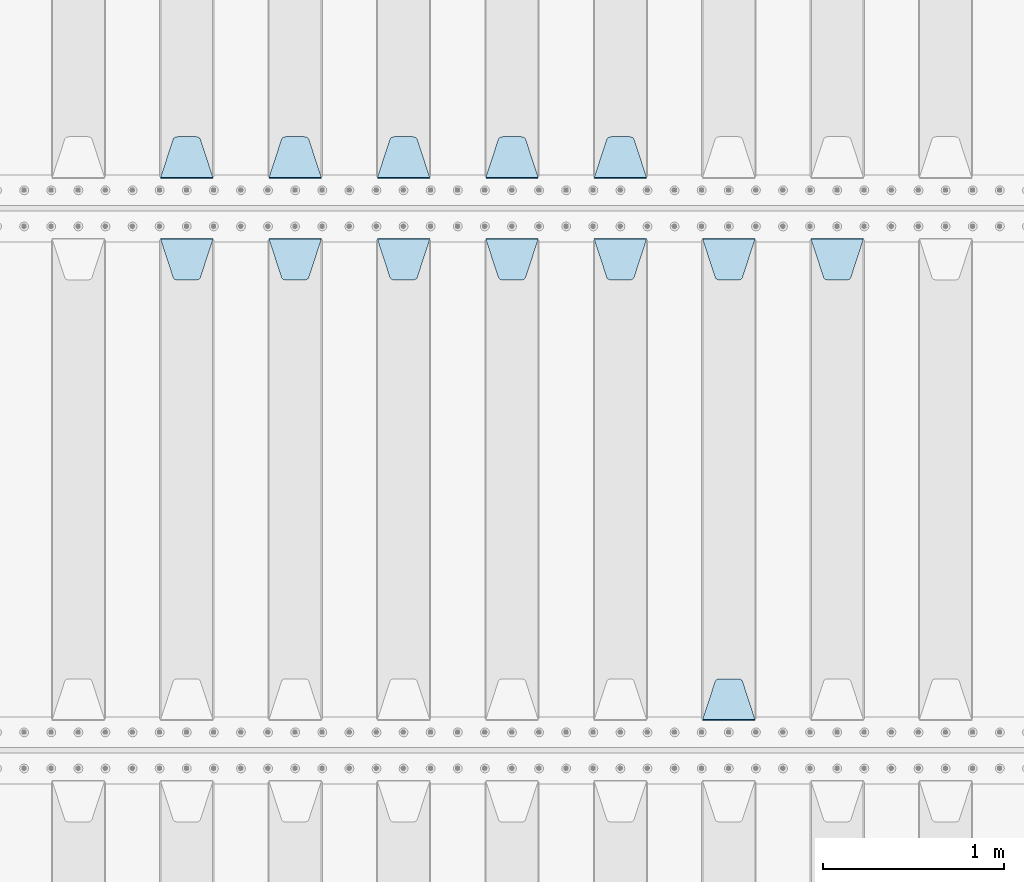
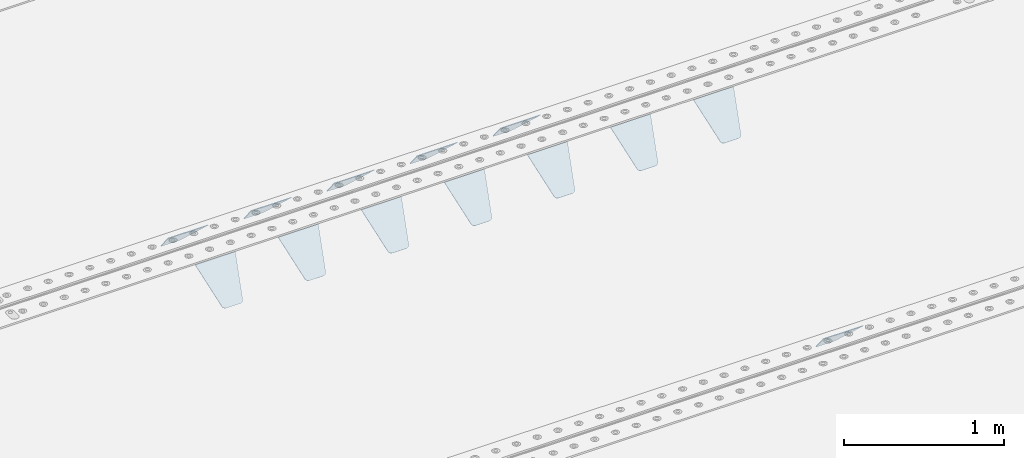
# One storey, part 214 of 257: 13 plates.
"""IFC2X3 building model written with IfcOpenShell, lengths in millimetres."""

from ifc_helpers import new_model, si_unit, frame, origin_with_axes, place, context, subcontext, project, spatial, faceted_brep, material, type_object, element, save


model = new_model("IFC2X3")

# Units and contexts
model_context = context("Model", 3, precision=1e-05, world=origin_with_axes())
body_context = subcontext(model_context, "Body", "Model", "MODEL_VIEW")
ifc_project = project(units=[si_unit("LENGTHUNIT", "METRE", prefix="MILLI"), si_unit("AREAUNIT", "SQUARE_METRE"), si_unit("VOLUMEUNIT", "CUBIC_METRE"), si_unit("MASSUNIT", "GRAM", prefix="KILO"), si_unit("TIMEUNIT", "SECOND"), si_unit("PLANEANGLEUNIT", "RADIAN"), si_unit("SOLIDANGLEUNIT", "STERADIAN"), si_unit("THERMODYNAMICTEMPERATUREUNIT", "DEGREE_CELSIUS"), si_unit("LUMINOUSINTENSITYUNIT", "LUMEN")], contexts=[model_context])

# Site, building, storey
site_placement = place(None, origin_with_axes())
site = spatial("IfcSite", under=ifc_project, at=site_placement, CompositionType="ELEMENT")
building_placement = place(site_placement, origin_with_axes())
building = spatial("IfcBuilding", under=site, at=building_placement, Name="Standard", CompositionType="ELEMENT")
storey_placement = place(building_placement, origin_with_axes())
storey = spatial("IfcBuildingStorey", under=building, at=storey_placement, Name="Undefined", CompositionType="ELEMENT", Elevation=0.0)

# Plates
ifc_material = material(Name="STEEL/S355N")
plate_type = type_object("IfcPlateType", PredefinedType="NOTDEFINED")
plate_1_placement = place(storey_placement, frame((51995.0, 6168.23223304703, -1.76776695296758), z_axis=(0.0, 0.707106781186547, -0.707106781186548), x_axis=(-1.0, 0.0, 0.0)))
element("IfcPlate", 1, at=plate_1_placement, inside=storey, type_object=plate_type, material=ifc_material, context=body_context, shape_type="Brep", body=[
    faceted_brep([(0.0, -2.5, 0.0), (69.345504679477, -2.50000000000091, 300.17173142483), (69.345504679477, 2.5, 300.171731424831), (0.0, 2.5, 0.0), (70.927406119954, -2.50000000000091, 304.8974424154), (70.927406119954, 2.5, 304.8974424154), (73.3818627772271, -2.50000000000091, 309.234538108527), (73.3818627772271, 2.49999999999909, 309.234538108527), (76.6187032999587, -2.5, 313.023683126103), (76.6187032999587, 2.5, 313.023683126103), (80.5190132705029, -2.5, 316.125672595372), (80.5190132705029, 2.5, 316.125672595371), (84.9395038596849, -2.5, 318.426546230476), (84.9395038596849, 2.5, 318.426546230477), (89.7177759439219, -2.5, 319.841774983275), (89.7177759439219, 2.5, 319.841774983275), (94.6782862926484, -2.5, 320.319366455079), (94.6782862926484, 2.5, 320.319366455079), (195.321713707352, -2.5, 320.319366455079), (195.321713707352, 2.5, 320.319366455079), (200.282224056078, -2.5, 319.841774983275), (200.282224056078, 2.49999999999909, 319.841774983275), (205.060496140315, -2.5, 318.426546230476), (205.060496140315, 2.49999999999909, 318.426546230475), (209.480986729497, -2.5, 316.125672595371), (209.480986729497, 2.5, 316.125672595371), (213.381296700041, -2.50000000000091, 313.023683126102), (213.381296700041, 2.5, 313.023683126103), (216.618137222766, -2.50000000000091, 309.234538108527), (216.618137222766, 2.5, 309.234538108527), (219.072593880039, -2.5, 304.897442415399), (219.072593880039, 2.5, 304.897442415399), (220.654495320523, -2.50000000000091, 300.17173142483), (220.654495320523, 2.5, 300.171731424831), (290.0, -2.50000000000091, 0.0), (290.0, 2.5, 9.09494701772928e-13)], [[[0, 1, 2, 3]], [[1, 4, 5, 2]], [[4, 6, 7, 5]], [[6, 8, 9, 7]], [[8, 10, 11, 9]], [[10, 12, 13, 11]], [[12, 14, 15, 13]], [[14, 16, 17, 15]], [[16, 18, 19, 17]], [[18, 20, 21, 19]], [[20, 22, 23, 21]], [[22, 24, 25, 23]], [[24, 26, 27, 25]], [[26, 28, 29, 27]], [[28, 30, 31, 29]], [[30, 32, 33, 31]], [[32, 34, 35, 33]], [[34, 0, 3, 35]], [[5, 7, 9, 11, 13, 15, 17, 19, 21, 23, 25, 27, 29, 31, 33, 35, 3, 2]], [[34, 32, 30, 28, 26, 24, 22, 20, 18, 16, 14, 12, 10, 8, 6, 4, 1, 0]]]),
])
plate_2_placement = place(storey_placement, frame((51395.0, 6168.23223304703, -1.76776695296758), z_axis=(0.0, 0.707106781186547, -0.707106781186548), x_axis=(-1.0, 0.0, 0.0)))
element("IfcPlate", 2, at=plate_2_placement, inside=storey, type_object=plate_type, material=ifc_material, context=body_context, shape_type="Brep", body=[
    faceted_brep([(0.0, -2.5, 0.0), (69.345504679477, -2.50000000000091, 300.17173142483), (69.345504679477, 2.5, 300.171731424831), (0.0, 2.5, 0.0), (70.927406119954, -2.50000000000091, 304.8974424154), (70.927406119954, 2.5, 304.8974424154), (73.3818627772271, -2.50000000000091, 309.234538108527), (73.3818627772271, 2.49999999999909, 309.234538108527), (76.6187032999587, -2.5, 313.023683126103), (76.6187032999587, 2.5, 313.023683126103), (80.5190132705029, -2.5, 316.125672595372), (80.5190132705029, 2.5, 316.125672595371), (84.9395038596849, -2.5, 318.426546230476), (84.9395038596849, 2.5, 318.426546230477), (89.7177759439219, -2.5, 319.841774983275), (89.7177759439219, 2.5, 319.841774983275), (94.6782862926484, -2.5, 320.319366455079), (94.6782862926484, 2.5, 320.319366455079), (195.321713707352, -2.5, 320.319366455079), (195.321713707352, 2.5, 320.319366455079), (200.282224056078, -2.5, 319.841774983275), (200.282224056078, 2.49999999999909, 319.841774983275), (205.060496140315, -2.5, 318.426546230476), (205.060496140315, 2.49999999999909, 318.426546230475), (209.480986729497, -2.5, 316.125672595371), (209.480986729497, 2.5, 316.125672595371), (213.381296700041, -2.50000000000091, 313.023683126102), (213.381296700041, 2.5, 313.023683126103), (216.618137222766, -2.50000000000091, 309.234538108527), (216.618137222766, 2.5, 309.234538108527), (219.072593880039, -2.5, 304.897442415399), (219.072593880039, 2.5, 304.897442415399), (220.654495320523, -2.50000000000091, 300.17173142483), (220.654495320523, 2.5, 300.171731424831), (290.0, -2.50000000000091, 0.0), (290.0, 2.5, 9.09494701772928e-13)], [[[0, 1, 2, 3]], [[1, 4, 5, 2]], [[4, 6, 7, 5]], [[6, 8, 9, 7]], [[8, 10, 11, 9]], [[10, 12, 13, 11]], [[12, 14, 15, 13]], [[14, 16, 17, 15]], [[16, 18, 19, 17]], [[18, 20, 21, 19]], [[20, 22, 23, 21]], [[22, 24, 25, 23]], [[24, 26, 27, 25]], [[26, 28, 29, 27]], [[28, 30, 31, 29]], [[30, 32, 33, 31]], [[32, 34, 35, 33]], [[34, 0, 3, 35]], [[5, 7, 9, 11, 13, 15, 17, 19, 21, 23, 25, 27, 29, 31, 33, 35, 3, 2]], [[34, 32, 30, 28, 26, 24, 22, 20, 18, 16, 14, 12, 10, 8, 6, 4, 1, 0]]]),
])
plate_3_placement = place(storey_placement, frame((50795.0, 6168.23223304703, -1.76776695296758), z_axis=(0.0, 0.707106781186547, -0.707106781186548), x_axis=(-1.0, 0.0, 0.0)))
element("IfcPlate", 3, at=plate_3_placement, inside=storey, type_object=plate_type, material=ifc_material, context=body_context, shape_type="Brep", body=[
    faceted_brep([(0.0, -2.5, 0.0), (69.345504679477, -2.50000000000091, 300.17173142483), (69.345504679477, 2.5, 300.171731424831), (0.0, 2.5, 0.0), (70.927406119954, -2.50000000000091, 304.8974424154), (70.927406119954, 2.5, 304.8974424154), (73.3818627772271, -2.50000000000091, 309.234538108527), (73.3818627772271, 2.49999999999909, 309.234538108527), (76.6187032999587, -2.5, 313.023683126103), (76.6187032999587, 2.5, 313.023683126103), (80.5190132705029, -2.5, 316.125672595372), (80.5190132705029, 2.5, 316.125672595371), (84.9395038596849, -2.5, 318.426546230476), (84.9395038596849, 2.5, 318.426546230477), (89.7177759439219, -2.5, 319.841774983275), (89.7177759439219, 2.5, 319.841774983275), (94.6782862926484, -2.5, 320.319366455079), (94.6782862926484, 2.5, 320.319366455079), (195.321713707352, -2.5, 320.319366455079), (195.321713707352, 2.5, 320.319366455079), (200.282224056078, -2.5, 319.841774983275), (200.282224056078, 2.49999999999909, 319.841774983275), (205.060496140315, -2.5, 318.426546230476), (205.060496140315, 2.49999999999909, 318.426546230475), (209.480986729497, -2.5, 316.125672595371), (209.480986729497, 2.5, 316.125672595371), (213.381296700041, -2.50000000000091, 313.023683126102), (213.381296700041, 2.5, 313.023683126103), (216.618137222766, -2.50000000000091, 309.234538108527), (216.618137222766, 2.5, 309.234538108527), (219.072593880039, -2.5, 304.897442415399), (219.072593880039, 2.5, 304.897442415399), (220.654495320523, -2.50000000000091, 300.17173142483), (220.654495320523, 2.5, 300.171731424831), (290.0, -2.50000000000091, 0.0), (290.0, 2.5, 9.09494701772928e-13)], [[[0, 1, 2, 3]], [[1, 4, 5, 2]], [[4, 6, 7, 5]], [[6, 8, 9, 7]], [[8, 10, 11, 9]], [[10, 12, 13, 11]], [[12, 14, 15, 13]], [[14, 16, 17, 15]], [[16, 18, 19, 17]], [[18, 20, 21, 19]], [[20, 22, 23, 21]], [[22, 24, 25, 23]], [[24, 26, 27, 25]], [[26, 28, 29, 27]], [[28, 30, 31, 29]], [[30, 32, 33, 31]], [[32, 34, 35, 33]], [[34, 0, 3, 35]], [[5, 7, 9, 11, 13, 15, 17, 19, 21, 23, 25, 27, 29, 31, 33, 35, 3, 2]], [[34, 32, 30, 28, 26, 24, 22, 20, 18, 16, 14, 12, 10, 8, 6, 4, 1, 0]]]),
])
plate_4_placement = place(storey_placement, frame((50195.0, 6168.23223304703, -1.76776695296758), z_axis=(0.0, 0.707106781186547, -0.707106781186548), x_axis=(-1.0, 0.0, 0.0)))
element("IfcPlate", 4, at=plate_4_placement, inside=storey, type_object=plate_type, material=ifc_material, context=body_context, shape_type="Brep", body=[
    faceted_brep([(0.0, -2.5, 0.0), (69.345504679477, -2.50000000000091, 300.17173142483), (69.345504679477, 2.5, 300.171731424831), (0.0, 2.5, 0.0), (70.927406119954, -2.50000000000091, 304.8974424154), (70.927406119954, 2.5, 304.8974424154), (73.3818627772271, -2.50000000000091, 309.234538108527), (73.3818627772271, 2.49999999999909, 309.234538108527), (76.6187032999587, -2.5, 313.023683126103), (76.6187032999587, 2.5, 313.023683126103), (80.5190132705029, -2.5, 316.125672595372), (80.5190132705029, 2.5, 316.125672595371), (84.9395038596849, -2.5, 318.426546230476), (84.9395038596849, 2.5, 318.426546230477), (89.7177759439219, -2.5, 319.841774983275), (89.7177759439219, 2.5, 319.841774983275), (94.6782862926484, -2.5, 320.319366455079), (94.6782862926484, 2.5, 320.319366455079), (195.321713707352, -2.5, 320.319366455079), (195.321713707352, 2.5, 320.319366455079), (200.282224056078, -2.5, 319.841774983275), (200.282224056078, 2.49999999999909, 319.841774983275), (205.060496140315, -2.5, 318.426546230476), (205.060496140315, 2.49999999999909, 318.426546230475), (209.480986729497, -2.5, 316.125672595371), (209.480986729497, 2.5, 316.125672595371), (213.381296700041, -2.50000000000091, 313.023683126102), (213.381296700041, 2.5, 313.023683126103), (216.618137222766, -2.50000000000091, 309.234538108527), (216.618137222766, 2.5, 309.234538108527), (219.072593880039, -2.5, 304.897442415399), (219.072593880039, 2.5, 304.897442415399), (220.654495320523, -2.50000000000091, 300.17173142483), (220.654495320523, 2.5, 300.171731424831), (290.0, -2.50000000000091, 0.0), (290.0, 2.5, 9.09494701772928e-13)], [[[0, 1, 2, 3]], [[1, 4, 5, 2]], [[4, 6, 7, 5]], [[6, 8, 9, 7]], [[8, 10, 11, 9]], [[10, 12, 13, 11]], [[12, 14, 15, 13]], [[14, 16, 17, 15]], [[16, 18, 19, 17]], [[18, 20, 21, 19]], [[20, 22, 23, 21]], [[22, 24, 25, 23]], [[24, 26, 27, 25]], [[26, 28, 29, 27]], [[28, 30, 31, 29]], [[30, 32, 33, 31]], [[32, 34, 35, 33]], [[34, 0, 3, 35]], [[5, 7, 9, 11, 13, 15, 17, 19, 21, 23, 25, 27, 29, 31, 33, 35, 3, 2]], [[34, 32, 30, 28, 26, 24, 22, 20, 18, 16, 14, 12, 10, 8, 6, 4, 1, 0]]]),
])
plate_5_placement = place(storey_placement, frame((49595.0, 6168.23223304703, -1.76776695296758), z_axis=(0.0, 0.707106781186547, -0.707106781186548), x_axis=(-1.0, 0.0, 0.0)))
element("IfcPlate", 5, at=plate_5_placement, inside=storey, type_object=plate_type, material=ifc_material, context=body_context, shape_type="Brep", body=[
    faceted_brep([(0.0, -2.5, 0.0), (69.345504679477, -2.50000000000091, 300.17173142483), (69.345504679477, 2.5, 300.171731424831), (0.0, 2.5, 0.0), (70.927406119954, -2.50000000000091, 304.8974424154), (70.927406119954, 2.5, 304.8974424154), (73.3818627772271, -2.50000000000091, 309.234538108527), (73.3818627772271, 2.49999999999909, 309.234538108527), (76.6187032999587, -2.5, 313.023683126103), (76.6187032999587, 2.5, 313.023683126103), (80.5190132705029, -2.5, 316.125672595372), (80.5190132705029, 2.5, 316.125672595371), (84.9395038596849, -2.5, 318.426546230476), (84.9395038596849, 2.5, 318.426546230477), (89.7177759439219, -2.5, 319.841774983275), (89.7177759439219, 2.5, 319.841774983275), (94.6782862926484, -2.5, 320.319366455079), (94.6782862926484, 2.5, 320.319366455079), (195.321713707352, -2.5, 320.319366455079), (195.321713707352, 2.5, 320.319366455079), (200.282224056078, -2.5, 319.841774983275), (200.282224056078, 2.49999999999909, 319.841774983275), (205.060496140315, -2.5, 318.426546230476), (205.060496140315, 2.49999999999909, 318.426546230475), (209.480986729497, -2.5, 316.125672595371), (209.480986729497, 2.5, 316.125672595371), (213.381296700041, -2.50000000000091, 313.023683126102), (213.381296700041, 2.5, 313.023683126103), (216.618137222766, -2.50000000000091, 309.234538108527), (216.618137222766, 2.5, 309.234538108527), (219.072593880039, -2.5, 304.897442415399), (219.072593880039, 2.5, 304.897442415399), (220.654495320523, -2.50000000000091, 300.17173142483), (220.654495320523, 2.5, 300.171731424831), (290.0, -2.50000000000091, 0.0), (290.0, 2.5, 9.09494701772928e-13)], [[[0, 1, 2, 3]], [[1, 4, 5, 2]], [[4, 6, 7, 5]], [[6, 8, 9, 7]], [[8, 10, 11, 9]], [[10, 12, 13, 11]], [[12, 14, 15, 13]], [[14, 16, 17, 15]], [[16, 18, 19, 17]], [[18, 20, 21, 19]], [[20, 22, 23, 21]], [[22, 24, 25, 23]], [[24, 26, 27, 25]], [[26, 28, 29, 27]], [[28, 30, 31, 29]], [[30, 32, 33, 31]], [[32, 34, 35, 33]], [[34, 0, 3, 35]], [[5, 7, 9, 11, 13, 15, 17, 19, 21, 23, 25, 27, 29, 31, 33, 35, 3, 2]], [[34, 32, 30, 28, 26, 24, 22, 20, 18, 16, 14, 12, 10, 8, 6, 4, 1, 0]]]),
])
plate_6_placement = place(storey_placement, frame((52905.0, 5831.76776695594, -1.767766952965), z_axis=(0.0, -0.707106781186548, -0.707106781186547), x_axis=(1.0, 0.0, 0.0)))
element("IfcPlate", 6, at=plate_6_placement, inside=storey, type_object=plate_type, material=ifc_material, context=body_context, shape_type="Brep", body=[
    faceted_brep([(0.0, -2.5, 0.0), (69.345504679477, -2.50000000000091, 300.17173142483), (69.345504679477, 2.5, 300.171731424831), (0.0, 2.5, 0.0), (70.927406119954, -2.50000000000091, 304.8974424154), (70.927406119954, 2.5, 304.8974424154), (73.3818627772271, -2.50000000000091, 309.234538108527), (73.3818627772271, 2.49999999999909, 309.234538108527), (76.6187032999587, -2.5, 313.023683126103), (76.6187032999587, 2.5, 313.023683126103), (80.5190132705029, -2.5, 316.125672595372), (80.5190132705029, 2.5, 316.125672595371), (84.9395038596849, -2.5, 318.426546230476), (84.9395038596849, 2.5, 318.426546230477), (89.7177759439219, -2.5, 319.841774983275), (89.7177759439219, 2.5, 319.841774983275), (94.6782862926484, -2.5, 320.319366455079), (94.6782862926484, 2.5, 320.319366455079), (195.321713707352, -2.5, 320.319366455079), (195.321713707352, 2.5, 320.319366455079), (200.282224056078, -2.5, 319.841774983275), (200.282224056078, 2.49999999999909, 319.841774983275), (205.060496140315, -2.5, 318.426546230476), (205.060496140315, 2.49999999999909, 318.426546230475), (209.480986729497, -2.5, 316.125672595371), (209.480986729497, 2.5, 316.125672595371), (213.381296700041, -2.50000000000091, 313.023683126102), (213.381296700041, 2.5, 313.023683126103), (216.618137222766, -2.50000000000091, 309.234538108527), (216.618137222766, 2.5, 309.234538108527), (219.072593880039, -2.5, 304.897442415399), (219.072593880039, 2.5, 304.897442415399), (220.654495320523, -2.50000000000091, 300.17173142483), (220.654495320523, 2.5, 300.171731424831), (290.0, -2.50000000000091, 0.0), (290.0, 2.5, 9.09494701772928e-13)], [[[0, 1, 2, 3]], [[1, 4, 5, 2]], [[4, 6, 7, 5]], [[6, 8, 9, 7]], [[8, 10, 11, 9]], [[10, 12, 13, 11]], [[12, 14, 15, 13]], [[14, 16, 17, 15]], [[16, 18, 19, 17]], [[18, 20, 21, 19]], [[20, 22, 23, 21]], [[22, 24, 25, 23]], [[24, 26, 27, 25]], [[26, 28, 29, 27]], [[28, 30, 31, 29]], [[30, 32, 33, 31]], [[32, 34, 35, 33]], [[34, 0, 3, 35]], [[5, 7, 9, 11, 13, 15, 17, 19, 21, 23, 25, 27, 29, 31, 33, 35, 3, 2]], [[34, 32, 30, 28, 26, 24, 22, 20, 18, 16, 14, 12, 10, 8, 6, 4, 1, 0]]]),
])
plate_7_placement = place(storey_placement, frame((52305.0, 5831.76776695594, -1.767766952965), z_axis=(0.0, -0.707106781186548, -0.707106781186547), x_axis=(1.0, 0.0, 0.0)))
element("IfcPlate", 7, at=plate_7_placement, inside=storey, type_object=plate_type, material=ifc_material, context=body_context, shape_type="Brep", body=[
    faceted_brep([(0.0, -2.5, 0.0), (69.345504679477, -2.50000000000091, 300.17173142483), (69.345504679477, 2.5, 300.171731424831), (0.0, 2.5, 0.0), (70.927406119954, -2.50000000000091, 304.8974424154), (70.927406119954, 2.5, 304.8974424154), (73.3818627772271, -2.50000000000091, 309.234538108527), (73.3818627772271, 2.49999999999909, 309.234538108527), (76.6187032999587, -2.5, 313.023683126103), (76.6187032999587, 2.5, 313.023683126103), (80.5190132705029, -2.5, 316.125672595372), (80.5190132705029, 2.5, 316.125672595371), (84.9395038596849, -2.5, 318.426546230476), (84.9395038596849, 2.5, 318.426546230477), (89.7177759439219, -2.5, 319.841774983275), (89.7177759439219, 2.5, 319.841774983275), (94.6782862926484, -2.5, 320.319366455079), (94.6782862926484, 2.5, 320.319366455079), (195.321713707352, -2.5, 320.319366455079), (195.321713707352, 2.5, 320.319366455079), (200.282224056078, -2.5, 319.841774983275), (200.282224056078, 2.49999999999909, 319.841774983275), (205.060496140315, -2.5, 318.426546230476), (205.060496140315, 2.49999999999909, 318.426546230475), (209.480986729497, -2.5, 316.125672595371), (209.480986729497, 2.5, 316.125672595371), (213.381296700041, -2.50000000000091, 313.023683126102), (213.381296700041, 2.5, 313.023683126103), (216.618137222766, -2.50000000000091, 309.234538108527), (216.618137222766, 2.5, 309.234538108527), (219.072593880039, -2.5, 304.897442415399), (219.072593880039, 2.5, 304.897442415399), (220.654495320523, -2.50000000000091, 300.17173142483), (220.654495320523, 2.5, 300.171731424831), (290.0, -2.50000000000091, 0.0), (290.0, 2.5, 9.09494701772928e-13)], [[[0, 1, 2, 3]], [[1, 4, 5, 2]], [[4, 6, 7, 5]], [[6, 8, 9, 7]], [[8, 10, 11, 9]], [[10, 12, 13, 11]], [[12, 14, 15, 13]], [[14, 16, 17, 15]], [[16, 18, 19, 17]], [[18, 20, 21, 19]], [[20, 22, 23, 21]], [[22, 24, 25, 23]], [[24, 26, 27, 25]], [[26, 28, 29, 27]], [[28, 30, 31, 29]], [[30, 32, 33, 31]], [[32, 34, 35, 33]], [[34, 0, 3, 35]], [[5, 7, 9, 11, 13, 15, 17, 19, 21, 23, 25, 27, 29, 31, 33, 35, 3, 2]], [[34, 32, 30, 28, 26, 24, 22, 20, 18, 16, 14, 12, 10, 8, 6, 4, 1, 0]]]),
])
plate_8_placement = place(storey_placement, frame((52595.0, 3168.23223304703, -1.76776695296758), z_axis=(0.0, 0.707106781186547, -0.707106781186548), x_axis=(-1.0, 0.0, 0.0)))
element("IfcPlate", 8, at=plate_8_placement, inside=storey, type_object=plate_type, material=ifc_material, context=body_context, shape_type="Brep", body=[
    faceted_brep([(0.0, -2.5, 0.0), (69.345504679477, -2.50000000000091, 300.17173142483), (69.345504679477, 2.5, 300.171731424831), (0.0, 2.5, 0.0), (70.927406119954, -2.50000000000091, 304.8974424154), (70.927406119954, 2.5, 304.8974424154), (73.3818627772271, -2.50000000000091, 309.234538108527), (73.3818627772271, 2.49999999999909, 309.234538108527), (76.6187032999587, -2.5, 313.023683126103), (76.6187032999587, 2.5, 313.023683126103), (80.5190132705029, -2.5, 316.125672595372), (80.5190132705029, 2.5, 316.125672595371), (84.9395038596849, -2.5, 318.426546230476), (84.9395038596849, 2.5, 318.426546230477), (89.7177759439219, -2.5, 319.841774983275), (89.7177759439219, 2.5, 319.841774983275), (94.6782862926484, -2.5, 320.319366455079), (94.6782862926484, 2.5, 320.319366455079), (195.321713707352, -2.5, 320.319366455079), (195.321713707352, 2.5, 320.319366455079), (200.282224056078, -2.5, 319.841774983275), (200.282224056078, 2.49999999999909, 319.841774983275), (205.060496140315, -2.5, 318.426546230476), (205.060496140315, 2.49999999999909, 318.426546230475), (209.480986729497, -2.5, 316.125672595371), (209.480986729497, 2.5, 316.125672595371), (213.381296700041, -2.50000000000091, 313.023683126102), (213.381296700041, 2.5, 313.023683126103), (216.618137222766, -2.50000000000091, 309.234538108527), (216.618137222766, 2.5, 309.234538108527), (219.072593880039, -2.5, 304.897442415399), (219.072593880039, 2.5, 304.897442415399), (220.654495320523, -2.50000000000091, 300.17173142483), (220.654495320523, 2.5, 300.171731424831), (290.0, -2.50000000000091, 0.0), (290.0, 2.5, 9.09494701772928e-13)], [[[0, 1, 2, 3]], [[1, 4, 5, 2]], [[4, 6, 7, 5]], [[6, 8, 9, 7]], [[8, 10, 11, 9]], [[10, 12, 13, 11]], [[12, 14, 15, 13]], [[14, 16, 17, 15]], [[16, 18, 19, 17]], [[18, 20, 21, 19]], [[20, 22, 23, 21]], [[22, 24, 25, 23]], [[24, 26, 27, 25]], [[26, 28, 29, 27]], [[28, 30, 31, 29]], [[30, 32, 33, 31]], [[32, 34, 35, 33]], [[34, 0, 3, 35]], [[5, 7, 9, 11, 13, 15, 17, 19, 21, 23, 25, 27, 29, 31, 33, 35, 3, 2]], [[34, 32, 30, 28, 26, 24, 22, 20, 18, 16, 14, 12, 10, 8, 6, 4, 1, 0]]]),
])
plate_9_placement = place(storey_placement, frame((51705.0, 5831.76776695594, -1.767766952965), z_axis=(0.0, -0.707106781186548, -0.707106781186547), x_axis=(1.0, 0.0, 0.0)))
element("IfcPlate", 9, at=plate_9_placement, inside=storey, type_object=plate_type, material=ifc_material, context=body_context, shape_type="Brep", body=[
    faceted_brep([(0.0, -2.5, 0.0), (69.345504679477, -2.50000000000091, 300.17173142483), (69.345504679477, 2.5, 300.171731424831), (0.0, 2.5, 0.0), (70.927406119954, -2.50000000000091, 304.8974424154), (70.927406119954, 2.5, 304.8974424154), (73.3818627772271, -2.50000000000091, 309.234538108527), (73.3818627772271, 2.49999999999909, 309.234538108527), (76.6187032999587, -2.5, 313.023683126103), (76.6187032999587, 2.5, 313.023683126103), (80.5190132705029, -2.5, 316.125672595372), (80.5190132705029, 2.5, 316.125672595371), (84.9395038596849, -2.5, 318.426546230476), (84.9395038596849, 2.5, 318.426546230477), (89.7177759439219, -2.5, 319.841774983275), (89.7177759439219, 2.5, 319.841774983275), (94.6782862926484, -2.5, 320.319366455079), (94.6782862926484, 2.5, 320.319366455079), (195.321713707352, -2.5, 320.319366455079), (195.321713707352, 2.5, 320.319366455079), (200.282224056078, -2.5, 319.841774983275), (200.282224056078, 2.49999999999909, 319.841774983275), (205.060496140315, -2.5, 318.426546230476), (205.060496140315, 2.49999999999909, 318.426546230475), (209.480986729497, -2.5, 316.125672595371), (209.480986729497, 2.5, 316.125672595371), (213.381296700041, -2.50000000000091, 313.023683126102), (213.381296700041, 2.5, 313.023683126103), (216.618137222766, -2.50000000000091, 309.234538108527), (216.618137222766, 2.5, 309.234538108527), (219.072593880039, -2.5, 304.897442415399), (219.072593880039, 2.5, 304.897442415399), (220.654495320523, -2.50000000000091, 300.17173142483), (220.654495320523, 2.5, 300.171731424831), (290.0, -2.50000000000091, 0.0), (290.0, 2.5, 9.09494701772928e-13)], [[[0, 1, 2, 3]], [[1, 4, 5, 2]], [[4, 6, 7, 5]], [[6, 8, 9, 7]], [[8, 10, 11, 9]], [[10, 12, 13, 11]], [[12, 14, 15, 13]], [[14, 16, 17, 15]], [[16, 18, 19, 17]], [[18, 20, 21, 19]], [[20, 22, 23, 21]], [[22, 24, 25, 23]], [[24, 26, 27, 25]], [[26, 28, 29, 27]], [[28, 30, 31, 29]], [[30, 32, 33, 31]], [[32, 34, 35, 33]], [[34, 0, 3, 35]], [[5, 7, 9, 11, 13, 15, 17, 19, 21, 23, 25, 27, 29, 31, 33, 35, 3, 2]], [[34, 32, 30, 28, 26, 24, 22, 20, 18, 16, 14, 12, 10, 8, 6, 4, 1, 0]]]),
])
plate_10_placement = place(storey_placement, frame((51105.0, 5831.76776695594, -1.767766952965), z_axis=(0.0, -0.707106781186548, -0.707106781186547), x_axis=(1.0, 0.0, 0.0)))
element("IfcPlate", 10, at=plate_10_placement, inside=storey, type_object=plate_type, material=ifc_material, context=body_context, shape_type="Brep", body=[
    faceted_brep([(0.0, -2.5, 0.0), (69.345504679477, -2.50000000000091, 300.17173142483), (69.345504679477, 2.5, 300.171731424831), (0.0, 2.5, 0.0), (70.927406119954, -2.50000000000091, 304.8974424154), (70.927406119954, 2.5, 304.8974424154), (73.3818627772271, -2.50000000000091, 309.234538108527), (73.3818627772271, 2.49999999999909, 309.234538108527), (76.6187032999587, -2.5, 313.023683126103), (76.6187032999587, 2.5, 313.023683126103), (80.5190132705029, -2.5, 316.125672595372), (80.5190132705029, 2.5, 316.125672595371), (84.9395038596849, -2.5, 318.426546230476), (84.9395038596849, 2.5, 318.426546230477), (89.7177759439219, -2.5, 319.841774983275), (89.7177759439219, 2.5, 319.841774983275), (94.6782862926484, -2.5, 320.319366455079), (94.6782862926484, 2.5, 320.319366455079), (195.321713707352, -2.5, 320.319366455079), (195.321713707352, 2.5, 320.319366455079), (200.282224056078, -2.5, 319.841774983275), (200.282224056078, 2.49999999999909, 319.841774983275), (205.060496140315, -2.5, 318.426546230476), (205.060496140315, 2.49999999999909, 318.426546230475), (209.480986729497, -2.5, 316.125672595371), (209.480986729497, 2.5, 316.125672595371), (213.381296700041, -2.50000000000091, 313.023683126102), (213.381296700041, 2.5, 313.023683126103), (216.618137222766, -2.50000000000091, 309.234538108527), (216.618137222766, 2.5, 309.234538108527), (219.072593880039, -2.5, 304.897442415399), (219.072593880039, 2.5, 304.897442415399), (220.654495320523, -2.50000000000091, 300.17173142483), (220.654495320523, 2.5, 300.171731424831), (290.0, -2.50000000000091, 0.0), (290.0, 2.5, 9.09494701772928e-13)], [[[0, 1, 2, 3]], [[1, 4, 5, 2]], [[4, 6, 7, 5]], [[6, 8, 9, 7]], [[8, 10, 11, 9]], [[10, 12, 13, 11]], [[12, 14, 15, 13]], [[14, 16, 17, 15]], [[16, 18, 19, 17]], [[18, 20, 21, 19]], [[20, 22, 23, 21]], [[22, 24, 25, 23]], [[24, 26, 27, 25]], [[26, 28, 29, 27]], [[28, 30, 31, 29]], [[30, 32, 33, 31]], [[32, 34, 35, 33]], [[34, 0, 3, 35]], [[5, 7, 9, 11, 13, 15, 17, 19, 21, 23, 25, 27, 29, 31, 33, 35, 3, 2]], [[34, 32, 30, 28, 26, 24, 22, 20, 18, 16, 14, 12, 10, 8, 6, 4, 1, 0]]]),
])
plate_11_placement = place(storey_placement, frame((50505.0, 5831.76776695594, -1.767766952965), z_axis=(0.0, -0.707106781186548, -0.707106781186547), x_axis=(1.0, 0.0, 0.0)))
element("IfcPlate", 11, at=plate_11_placement, inside=storey, type_object=plate_type, material=ifc_material, context=body_context, shape_type="Brep", body=[
    faceted_brep([(0.0, -2.5, 0.0), (69.345504679477, -2.50000000000091, 300.17173142483), (69.345504679477, 2.5, 300.171731424831), (0.0, 2.5, 0.0), (70.927406119954, -2.50000000000091, 304.8974424154), (70.927406119954, 2.5, 304.8974424154), (73.3818627772271, -2.50000000000091, 309.234538108527), (73.3818627772271, 2.49999999999909, 309.234538108527), (76.6187032999587, -2.5, 313.023683126103), (76.6187032999587, 2.5, 313.023683126103), (80.5190132705029, -2.5, 316.125672595372), (80.5190132705029, 2.5, 316.125672595371), (84.9395038596849, -2.5, 318.426546230476), (84.9395038596849, 2.5, 318.426546230477), (89.7177759439219, -2.5, 319.841774983275), (89.7177759439219, 2.5, 319.841774983275), (94.6782862926484, -2.5, 320.319366455079), (94.6782862926484, 2.5, 320.319366455079), (195.321713707352, -2.5, 320.319366455079), (195.321713707352, 2.5, 320.319366455079), (200.282224056078, -2.5, 319.841774983275), (200.282224056078, 2.49999999999909, 319.841774983275), (205.060496140315, -2.5, 318.426546230476), (205.060496140315, 2.49999999999909, 318.426546230475), (209.480986729497, -2.5, 316.125672595371), (209.480986729497, 2.5, 316.125672595371), (213.381296700041, -2.50000000000091, 313.023683126102), (213.381296700041, 2.5, 313.023683126103), (216.618137222766, -2.50000000000091, 309.234538108527), (216.618137222766, 2.5, 309.234538108527), (219.072593880039, -2.5, 304.897442415399), (219.072593880039, 2.5, 304.897442415399), (220.654495320523, -2.50000000000091, 300.17173142483), (220.654495320523, 2.5, 300.171731424831), (290.0, -2.50000000000091, 0.0), (290.0, 2.5, 9.09494701772928e-13)], [[[0, 1, 2, 3]], [[1, 4, 5, 2]], [[4, 6, 7, 5]], [[6, 8, 9, 7]], [[8, 10, 11, 9]], [[10, 12, 13, 11]], [[12, 14, 15, 13]], [[14, 16, 17, 15]], [[16, 18, 19, 17]], [[18, 20, 21, 19]], [[20, 22, 23, 21]], [[22, 24, 25, 23]], [[24, 26, 27, 25]], [[26, 28, 29, 27]], [[28, 30, 31, 29]], [[30, 32, 33, 31]], [[32, 34, 35, 33]], [[34, 0, 3, 35]], [[5, 7, 9, 11, 13, 15, 17, 19, 21, 23, 25, 27, 29, 31, 33, 35, 3, 2]], [[34, 32, 30, 28, 26, 24, 22, 20, 18, 16, 14, 12, 10, 8, 6, 4, 1, 0]]]),
])
plate_12_placement = place(storey_placement, frame((49905.0, 5831.76776695594, -1.767766952965), z_axis=(0.0, -0.707106781186548, -0.707106781186547), x_axis=(1.0, 0.0, 0.0)))
element("IfcPlate", 12, at=plate_12_placement, inside=storey, type_object=plate_type, material=ifc_material, context=body_context, shape_type="Brep", body=[
    faceted_brep([(0.0, -2.5, 0.0), (69.345504679477, -2.50000000000091, 300.17173142483), (69.345504679477, 2.5, 300.171731424831), (0.0, 2.5, 0.0), (70.927406119954, -2.50000000000091, 304.8974424154), (70.927406119954, 2.5, 304.8974424154), (73.3818627772271, -2.50000000000091, 309.234538108527), (73.3818627772271, 2.49999999999909, 309.234538108527), (76.6187032999587, -2.5, 313.023683126103), (76.6187032999587, 2.5, 313.023683126103), (80.5190132705029, -2.5, 316.125672595372), (80.5190132705029, 2.5, 316.125672595371), (84.9395038596849, -2.5, 318.426546230476), (84.9395038596849, 2.5, 318.426546230477), (89.7177759439219, -2.5, 319.841774983275), (89.7177759439219, 2.5, 319.841774983275), (94.6782862926484, -2.5, 320.319366455079), (94.6782862926484, 2.5, 320.319366455079), (195.321713707352, -2.5, 320.319366455079), (195.321713707352, 2.5, 320.319366455079), (200.282224056078, -2.5, 319.841774983275), (200.282224056078, 2.49999999999909, 319.841774983275), (205.060496140315, -2.5, 318.426546230476), (205.060496140315, 2.49999999999909, 318.426546230475), (209.480986729497, -2.5, 316.125672595371), (209.480986729497, 2.5, 316.125672595371), (213.381296700041, -2.50000000000091, 313.023683126102), (213.381296700041, 2.5, 313.023683126103), (216.618137222766, -2.50000000000091, 309.234538108527), (216.618137222766, 2.5, 309.234538108527), (219.072593880039, -2.5, 304.897442415399), (219.072593880039, 2.5, 304.897442415399), (220.654495320523, -2.50000000000091, 300.17173142483), (220.654495320523, 2.5, 300.171731424831), (290.0, -2.50000000000091, 0.0), (290.0, 2.5, 9.09494701772928e-13)], [[[0, 1, 2, 3]], [[1, 4, 5, 2]], [[4, 6, 7, 5]], [[6, 8, 9, 7]], [[8, 10, 11, 9]], [[10, 12, 13, 11]], [[12, 14, 15, 13]], [[14, 16, 17, 15]], [[16, 18, 19, 17]], [[18, 20, 21, 19]], [[20, 22, 23, 21]], [[22, 24, 25, 23]], [[24, 26, 27, 25]], [[26, 28, 29, 27]], [[28, 30, 31, 29]], [[30, 32, 33, 31]], [[32, 34, 35, 33]], [[34, 0, 3, 35]], [[5, 7, 9, 11, 13, 15, 17, 19, 21, 23, 25, 27, 29, 31, 33, 35, 3, 2]], [[34, 32, 30, 28, 26, 24, 22, 20, 18, 16, 14, 12, 10, 8, 6, 4, 1, 0]]]),
])
plate_13_placement = place(storey_placement, frame((49305.0, 5831.76776695594, -1.767766952965), z_axis=(0.0, -0.707106781186548, -0.707106781186547), x_axis=(1.0, 0.0, 0.0)))
element("IfcPlate", 13, at=plate_13_placement, inside=storey, type_object=plate_type, material=ifc_material, context=body_context, shape_type="Brep", body=[
    faceted_brep([(0.0, -2.5, 0.0), (69.345504679477, -2.50000000000091, 300.17173142483), (69.345504679477, 2.5, 300.171731424831), (0.0, 2.5, 0.0), (70.927406119954, -2.50000000000091, 304.8974424154), (70.927406119954, 2.5, 304.8974424154), (73.3818627772271, -2.50000000000091, 309.234538108527), (73.3818627772271, 2.49999999999909, 309.234538108527), (76.6187032999587, -2.5, 313.023683126103), (76.6187032999587, 2.5, 313.023683126103), (80.5190132705029, -2.5, 316.125672595372), (80.5190132705029, 2.5, 316.125672595371), (84.9395038596849, -2.5, 318.426546230476), (84.9395038596849, 2.5, 318.426546230477), (89.7177759439219, -2.5, 319.841774983275), (89.7177759439219, 2.5, 319.841774983275), (94.6782862926484, -2.5, 320.319366455079), (94.6782862926484, 2.5, 320.319366455079), (195.321713707352, -2.5, 320.319366455079), (195.321713707352, 2.5, 320.319366455079), (200.282224056078, -2.5, 319.841774983275), (200.282224056078, 2.49999999999909, 319.841774983275), (205.060496140315, -2.5, 318.426546230476), (205.060496140315, 2.49999999999909, 318.426546230475), (209.480986729497, -2.5, 316.125672595371), (209.480986729497, 2.5, 316.125672595371), (213.381296700041, -2.50000000000091, 313.023683126102), (213.381296700041, 2.5, 313.023683126103), (216.618137222766, -2.50000000000091, 309.234538108527), (216.618137222766, 2.5, 309.234538108527), (219.072593880039, -2.5, 304.897442415399), (219.072593880039, 2.5, 304.897442415399), (220.654495320523, -2.50000000000091, 300.17173142483), (220.654495320523, 2.5, 300.171731424831), (290.0, -2.50000000000091, 0.0), (290.0, 2.5, 9.09494701772928e-13)], [[[0, 1, 2, 3]], [[1, 4, 5, 2]], [[4, 6, 7, 5]], [[6, 8, 9, 7]], [[8, 10, 11, 9]], [[10, 12, 13, 11]], [[12, 14, 15, 13]], [[14, 16, 17, 15]], [[16, 18, 19, 17]], [[18, 20, 21, 19]], [[20, 22, 23, 21]], [[22, 24, 25, 23]], [[24, 26, 27, 25]], [[26, 28, 29, 27]], [[28, 30, 31, 29]], [[30, 32, 33, 31]], [[32, 34, 35, 33]], [[34, 0, 3, 35]], [[5, 7, 9, 11, 13, 15, 17, 19, 21, 23, 25, 27, 29, 31, 33, 35, 3, 2]], [[34, 32, 30, 28, 26, 24, 22, 20, 18, 16, 14, 12, 10, 8, 6, 4, 1, 0]]]),
])

save(model, "model.ifc")
